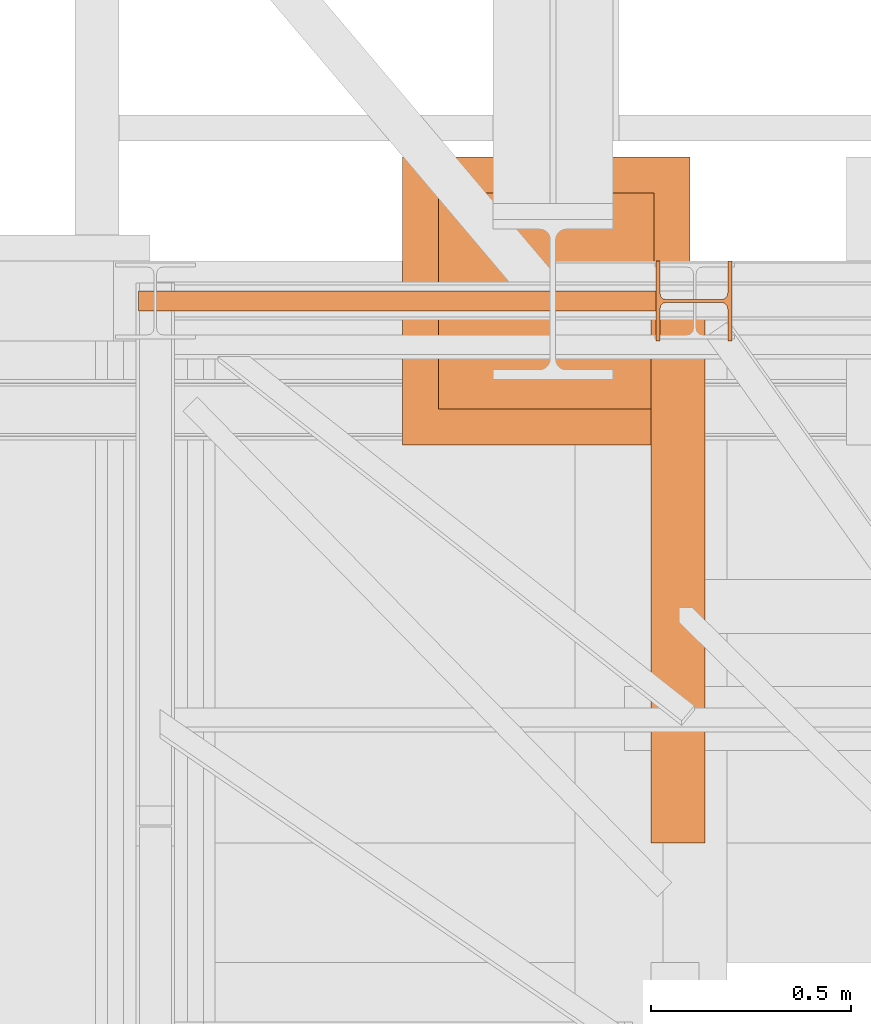
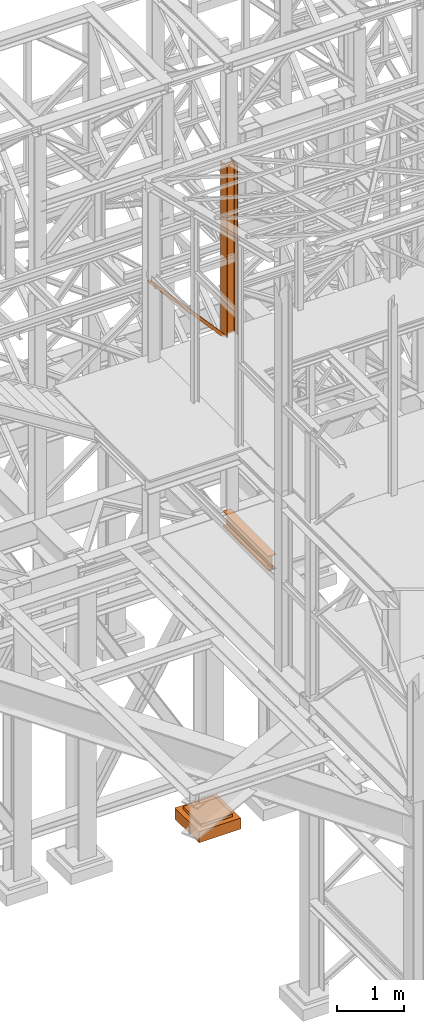
# One storey, part 36 of 208: 4 proxies.
"""IFC2X3 building model written with IfcOpenShell, lengths in millimetres."""

from ifc_helpers import new_model, entity, si_unit, converted_unit, frame, origin, origin_with_axes, place, context, subcontext, project, spatial, faceted_brep, element, save


model = new_model("IFC2X3")

# Units and contexts
model_context = context("Model", 3, precision=1e-05, world=origin())
plan_context = context("Plan", 3, precision=1e-05, world=origin())
body_context = subcontext(model_context, "Body", "Model", "MODEL_VIEW")
ifc_project = project(units=[si_unit("LENGTHUNIT", "METRE", prefix="MILLI"), converted_unit("PLANEANGLEUNIT", "DEGREE", entity("IfcPlaneAngleMeasure", 0.0174532925199433), si_unit("PLANEANGLEUNIT", "RADIAN"), dimensions=[0, 0, 0, 0, 0, 0, 0]), si_unit("AREAUNIT", "SQUARE_METRE"), si_unit("VOLUMEUNIT", "CUBIC_METRE")], contexts=[model_context, plan_context])

# Building, storey
building_placement = place(None, origin())
building = spatial("IfcBuilding", under=ifc_project, at=building_placement, CompositionType="COMPLEX")
storey_placement = place(building_placement, origin_with_axes())
storey = spatial("IfcBuildingStorey", under=building, at=storey_placement, Name="Geschoss", CompositionType="ELEMENT")

# Proxies
proxy_1_placement = place(storey_placement, frame((2438.254968338675, -18618.5743901279, 5014.990005364416), z_axis=(0.0, 0.0, 1.0), x_axis=(1.0, 0.0, 0.0)))
element("IfcBuildingElementProxy", 1, at=proxy_1_placement, inside=storey, context=body_context, shape_type="Brep", body=[
    faceted_brep([(135.0100000000002, 0.01000000000203727, 270.0100000000002), (135.0100000000002, 1361.080528322538, 270.0099999999993), (135.0100000000002, 1361.080528322538, 259.8100001907342), (135.0100000000002, 0.01000000000203727, 259.8100001907342), (135.0100000000002, 0.01000000000203727, 259.8100001907342), (135.0100000000002, 1361.080528322538, 259.8100001907342), (85.8099999523165, 1361.080528322538, 259.8100001907351), (85.8099999523165, 0.01000000000203727, 259.8100001907342), (85.8099999523165, 0.01000000000203727, 259.8100001907342), (85.8099999523165, 1361.080528322538, 259.8100001907351), (81.17476076017192, 1361.080528322538, 259.0757968253229), (81.17476076017192, 0.01000000000203727, 259.0757968253229), (81.17476076017192, 0.01000000000203727, 259.0757968253229), (81.17476076017192, 1361.080528322538, 259.0757968253229), (76.99323602687218, 1361.080528322538, 256.9452365592915), (76.99323602687218, 0.01000000000203727, 256.9452365592915), (76.99323602687218, 0.01000000000203727, 256.9452365592915), (76.99323602687218, 1361.080528322538, 256.9452365592915), (73.67476358376007, 1361.080528322538, 253.6267641161794), (73.67476358376007, 0.01000000000203727, 253.6267641161794), (73.67476358376007, 0.01000000000203727, 253.6267641161794), (73.67476358376007, 1361.080528322538, 253.6267641161794), (71.5442033177278, 1361.080528322538, 249.4452393828788), (71.5442033177278, 0.01000000000203727, 249.4452393828788), (71.5442033177278, 0.01000000000203727, 249.4452393828788), (71.5442033177278, 1361.080528322538, 249.4452393828788), (70.8099999523165, 1361.080528322538, 244.8100001907342), (70.8099999523165, 0.01000000000203727, 244.8100001907342), (70.8099999523165, 0.01000000000203727, 244.8100001907342), (70.8099999523165, 1361.080528322538, 244.8100001907342), (70.8099999523165, 1361.080528322538, 25.20999980926445), (70.8099999523165, 0.01000000000203727, 25.20999980926445), (70.8099999523165, 0.01000000000203727, 25.20999980926445), (70.8099999523165, 1361.080528322538, 25.20999980926445), (71.5442033177278, 1361.080528322538, 20.57476061711986), (71.5442033177278, 0.01000000000203727, 20.57476061711896), (71.5442033177278, 0.01000000000203727, 20.57476061711896), (71.5442033177278, 1361.080528322538, 20.57476061711986), (73.67476358376007, 1361.080528322538, 16.39323588381922), (73.67476358376007, 0.01000000000203727, 16.39323588381922), (73.67476358376007, 0.01000000000203727, 16.39323588381922), (73.67476358376007, 1361.080528322538, 16.39323588381922), (76.99323602687218, 1361.080528322538, 13.07476344070801), (76.99323602687218, 0.01000000000203727, 13.07476344070801), (76.99323602687218, 0.01000000000203727, 13.07476344070801), (76.99323602687218, 1361.080528322538, 13.07476344070801), (81.17476076017192, 1361.080528322538, 10.94420317467666), (81.17476076017192, 0.01000000000203727, 10.94420317467666), (81.17476076017192, 0.01000000000203727, 10.94420317467666), (81.17476076017192, 1361.080528322538, 10.94420317467666), (85.8099999523165, 1361.080528322538, 10.20999980926445), (85.8099999523165, 0.01000000000203727, 10.20999980926445), (85.8099999523165, 0.01000000000203727, 10.20999980926445), (85.8099999523165, 1361.080528322538, 10.20999980926445), (135.0100000000002, 1361.080528322538, 10.20999980926445), (135.0100000000002, 0.01000000000203727, 10.20999980926445), (135.0100000000002, 0.01000000000203727, 10.20999980926445), (135.0100000000002, 1361.080528322538, 10.20999980926445), (135.0100000000002, 1361.080528322538, 0.009999999999308784), (135.0100000000002, 0.01000000000203727, 0.01000000000021828), (135.0100000000002, 0.01000000000203727, 0.01000000000021828), (135.0100000000002, 1361.080528322538, 0.009999999999308784), (0.01000000000021828, 1361.080528322538, 0.009999999999308784), (0.01000000000021828, 0.01000000000203727, 0.01000000000021828), (0.01000000000021828, 0.01000000000203727, 0.01000000000021828), (0.01000000000021828, 1361.080528322538, 0.009999999999308784), (0.01000000000021828, 1361.080528322538, 10.20999980926536), (0.01000000000021828, 0.01000000000203727, 10.20999980926536), (0.01000000000021828, 0.01000000000203727, 10.20999980926536), (0.01000000000021828, 1361.080528322538, 10.20999980926536), (49.21000004768393, 1361.080528322538, 10.20999980926445), (49.21000004768393, 0.01000000000203727, 10.20999980926445), (49.21000004768393, 0.01000000000203727, 10.20999980926445), (49.21000004768393, 1361.080528322538, 10.20999980926445), (53.09227270367228, 1361.080528322538, 10.72115637176103), (53.09227270367228, 0.01000000000203727, 10.72115637176103), (53.09227270367228, 0.01000000000203727, 10.72115637176103), (53.09227270367228, 1361.080528322538, 10.72115637176103), (56.70997817243006, 1361.080528322538, 12.21965904159151), (56.70997817243006, 0.01000000000203727, 12.21965904159151), (56.70997817243006, 0.01000000000203727, 12.21965904159151), (56.70997817243006, 1361.080528322538, 12.21965904159151), (59.81660176548212, 1361.080528322538, 14.60339809146626), (59.81660176548212, 0.01000000000203727, 14.60339809146626), (59.81660176548212, 0.01000000000203727, 14.60339809146626), (59.81660176548212, 1361.080528322538, 14.60339809146626), (62.20034081535778, 1361.080528322538, 17.71002168451923), (62.20034081535778, 0.01000000000203727, 17.71002168451923), (62.20034081535778, 0.01000000000203727, 17.71002168451923), (62.20034081535778, 1361.080528322538, 17.71002168451923), (63.69884348518826, 1361.080528322538, 21.32772715327701), (63.69884348518826, 0.01000000000203727, 21.32772715327701), (63.69884348518826, 0.01000000000203727, 21.32772715327701), (63.69884348518826, 1361.080528322538, 21.32772715327701), (64.21000004768393, 1361.080528322538, 25.20999980926445), (64.21000004768393, 0.01000000000203727, 25.20999980926445), (64.21000004768393, 0.01000000000203727, 25.20999980926445), (64.21000004768393, 1361.080528322538, 25.20999980926445), (64.21000004768393, 1361.080528322538, 244.8100001907342), (64.21000004768393, 0.01000000000203727, 244.8100001907342), (64.21000004768393, 0.01000000000203727, 244.8100001907342), (64.21000004768393, 1361.080528322538, 244.8100001907342), (63.47579668227263, 1361.080528322538, 249.4452393828788), (63.47579668227263, 0.01000000000203727, 249.4452393828788), (63.47579668227263, 0.01000000000203727, 249.4452393828788), (63.47579668227263, 1361.080528322538, 249.4452393828788), (61.34523641624219, 1361.080528322538, 253.6267641161794), (61.34523641624219, 0.01000000000203727, 253.6267641161794), (61.34523641624219, 0.01000000000203727, 253.6267641161794), (61.34523641624219, 1361.080528322538, 253.6267641161794), (58.02676397313007, 1361.080528322538, 256.9452365592915), (58.02676397313007, 0.01000000000203727, 256.9452365592915), (58.02676397313007, 0.01000000000203727, 256.9452365592915), (58.02676397313007, 1361.080528322538, 256.9452365592915), (53.84523923982852, 1361.080528322538, 259.0757968253229), (53.84523923982852, 0.01000000000203727, 259.0757968253229), (53.84523923982852, 0.01000000000203727, 259.0757968253229), (53.84523923982852, 1361.080528322538, 259.0757968253229), (49.21000004768393, 1361.080528322538, 259.8100001907351), (49.21000004768393, 0.01000000000203727, 259.8100001907342), (49.21000004768393, 0.01000000000203727, 259.8100001907342), (49.21000004768393, 1361.080528322538, 259.8100001907351), (0.01000000000021828, 1361.080528322538, 259.8100001907351), (0.01000000000021828, 0.01000000000203727, 259.8100001907342), (0.01000000000021828, 0.01000000000203727, 259.8100001907342), (0.01000000000021828, 1361.080528322538, 259.8100001907351), (0.01000000000021828, 1361.080528322538, 270.0099999999993), (0.01000000000021828, 0.01000000000203727, 270.0099999999993), (0.01000000000021828, 0.01000000000203727, 270.0099999999993), (0.01000000000021828, 1361.080528322538, 270.0099999999993), (135.0100000000002, 1361.080528322538, 270.0099999999993), (135.0100000000002, 0.01000000000203727, 270.0100000000002), (53.84523923982852, 1361.080528322538, 259.0757968253229), (58.02676397313007, 1361.080528322538, 256.9452365592915), (61.34523641624219, 1361.080528322538, 253.6267641161794), (63.47579668227263, 1361.080528322538, 249.4452393828788), (64.21000004768393, 1361.080528322538, 244.8100001907342), (64.21000004768393, 1361.080528322538, 25.20999980926445), (63.69884348518826, 1361.080528322538, 21.32772715327701), (62.20034081535778, 1361.080528322538, 17.71002168451923), (59.81660176548212, 1361.080528322538, 14.60339809146626), (56.70997817243006, 1361.080528322538, 12.21965904159151), (53.09227270367228, 1361.080528322538, 10.72115637176103), (49.21000004768393, 1361.080528322538, 10.20999980926445), (0.01000000000021828, 1361.080528322538, 10.20999980926536), (0.01000000000021828, 1361.080528322538, 0.009999999999308784), (135.0100000000002, 1361.080528322538, 0.009999999999308784), (135.0100000000002, 1361.080528322538, 10.20999980926445), (85.8099999523165, 1361.080528322538, 10.20999980926445), (81.17476076017192, 1361.080528322538, 10.94420317467666), (76.99323602687218, 1361.080528322538, 13.07476344070801), (73.67476358376007, 1361.080528322538, 16.39323588381922), (71.5442033177278, 1361.080528322538, 20.57476061711986), (70.8099999523165, 1361.080528322538, 25.20999980926445), (70.8099999523165, 1361.080528322538, 244.8100001907342), (71.5442033177278, 1361.080528322538, 249.4452393828788), (73.67476358376007, 1361.080528322538, 253.6267641161794), (76.99323602687218, 1361.080528322538, 256.9452365592915), (81.17476076017192, 1361.080528322538, 259.0757968253229), (85.8099999523165, 1361.080528322538, 259.8100001907351), (135.0100000000002, 1361.080528322538, 259.8100001907342), (135.0100000000002, 1361.080528322538, 270.0099999999993), (0.01000000000021828, 1361.080528322538, 270.0099999999993), (0.01000000000021828, 1361.080528322538, 259.8100001907351), (49.21000004768393, 1361.080528322538, 259.8100001907351), (135.0100000000002, 0.01000000000203727, 270.0100000000002), (135.0100000000002, 0.01000000000203727, 259.8100001907342), (85.8099999523165, 0.01000000000203727, 259.8100001907342), (81.17476076017192, 0.01000000000203727, 259.0757968253229), (76.99323602687218, 0.01000000000203727, 256.9452365592915), (73.67476358376007, 0.01000000000203727, 253.6267641161794), (71.5442033177278, 0.01000000000203727, 249.4452393828788), (70.8099999523165, 0.01000000000203727, 244.8100001907342), (70.8099999523165, 0.01000000000203727, 25.20999980926445), (71.5442033177278, 0.01000000000203727, 20.57476061711896), (73.67476358376007, 0.01000000000203727, 16.39323588381922), (76.99323602687218, 0.01000000000203727, 13.07476344070801), (81.17476076017192, 0.01000000000203727, 10.94420317467666), (85.8099999523165, 0.01000000000203727, 10.20999980926445), (135.0100000000002, 0.01000000000203727, 10.20999980926445), (135.0100000000002, 0.01000000000203727, 0.01000000000021828), (0.01000000000021828, 0.01000000000203727, 0.01000000000021828), (0.01000000000021828, 0.01000000000203727, 10.20999980926536), (49.21000004768393, 0.01000000000203727, 10.20999980926445), (53.09227270367228, 0.01000000000203727, 10.72115637176103), (56.70997817243006, 0.01000000000203727, 12.21965904159151), (59.81660176548212, 0.01000000000203727, 14.60339809146626), (62.20034081535778, 0.01000000000203727, 17.71002168451923), (63.69884348518826, 0.01000000000203727, 21.32772715327701), (64.21000004768393, 0.01000000000203727, 25.20999980926445), (64.21000004768393, 0.01000000000203727, 244.8100001907342), (63.47579668227263, 0.01000000000203727, 249.4452393828788), (61.34523641624219, 0.01000000000203727, 253.6267641161794), (58.02676397313007, 0.01000000000203727, 256.9452365592915), (53.84523923982852, 0.01000000000203727, 259.0757968253229), (49.21000004768393, 0.01000000000203727, 259.8100001907342), (0.01000000000021828, 0.01000000000203727, 259.8100001907342), (0.01000000000021828, 0.01000000000203727, 270.0099999999993)], [[[0, 1, 2, 3]], [[4, 5, 6, 7]], [[8, 9, 10, 11]], [[12, 13, 14, 15]], [[16, 17, 18, 19]], [[20, 21, 22, 23]], [[24, 25, 26, 27]], [[28, 29, 30, 31]], [[32, 33, 34, 35]], [[36, 37, 38, 39]], [[40, 41, 42, 43]], [[44, 45, 46, 47]], [[48, 49, 50, 51]], [[52, 53, 54, 55]], [[56, 57, 58, 59]], [[60, 61, 62, 63]], [[64, 65, 66, 67]], [[68, 69, 70, 71]], [[72, 73, 74, 75]], [[76, 77, 78, 79]], [[80, 81, 82, 83]], [[84, 85, 86, 87]], [[88, 89, 90, 91]], [[92, 93, 94, 95]], [[96, 97, 98, 99]], [[100, 101, 102, 103]], [[104, 105, 106, 107]], [[108, 109, 110, 111]], [[112, 113, 114, 115]], [[116, 117, 118, 119]], [[120, 121, 122, 123]], [[124, 125, 126, 127]], [[128, 129, 130, 131]], [[132, 133, 134, 135, 136, 137, 138, 139, 140, 141, 142, 143, 144, 145, 146, 147, 148, 149, 150, 151, 152, 153, 154, 155, 156, 157, 158, 159, 160, 161, 162, 163, 164]], [[165, 166, 167, 168, 169, 170, 171, 172, 173, 174, 175, 176, 177, 178, 179, 180, 181, 182, 183, 184, 185, 186, 187, 188, 189, 190, 191, 192, 193, 194, 195, 196, 197]]], orient=[[False], [False], [False], [False], [False], [False], [False], [False], [False], [False], [False], [False], [False], [False], [False], [False], [False], [False], [False], [False], [False], [False], [False], [False], [False], [False], [False], [False], [False], [False], [False], [False], [False], [False], [False]]),
])
proxy_2_placement = place(storey_placement, frame((1816.730231152619, -17622.57439531565, -315.0099999999999), z_axis=(0.0, 0.0, 1.0), x_axis=(1.0, 0.0, 0.0)))
element("IfcBuildingElementProxy", 2, at=proxy_2_placement, inside=storey, context=body_context, shape_type="Brep", body=[
    faceted_brep([(630.01, 630.0099999999984, 250.01), (630.01, 90.0099999999984, 250.01), (90.00999999999999, 90.0099999999984, 250.01), (90.00999999999999, 630.0099999999984, 250.01), (630.01, 630.0099999999984, 200.01), (630.01, 90.0099999999984, 200.01), (630.01, 90.0099999999984, 250.01), (630.01, 630.0099999999984, 250.01), (90.00999999999999, 630.0099999999984, 200.01), (630.01, 630.0099999999984, 200.01), (630.01, 630.0099999999984, 250.01), (90.00999999999999, 630.0099999999984, 250.01), (90.00999999999999, 90.0099999999984, 200.01), (90.00999999999999, 630.0099999999984, 200.01), (90.00999999999999, 630.0099999999984, 250.01), (90.00999999999999, 90.0099999999984, 250.01), (630.01, 90.0099999999984, 200.01), (90.00999999999999, 90.0099999999984, 200.01), (90.00999999999999, 90.0099999999984, 250.01), (630.01, 90.0099999999984, 250.01), (720.01, 0.00999999999839929, 0.009999999999990905), (720.01, 720.0099999999984, 0.009999999999990905), (0.009999999999990905, 720.0099999999984, 0.009999999999990905), (0.009999999999990905, 0.00999999999839929, 0.009999999999990905), (720.01, 720.0099999999984, 200.01), (720.01, 0.00999999999839929, 200.01), (0.009999999999990905, 0.00999999999839929, 200.01), (0.009999999999990905, 720.0099999999984, 200.01), (90.00999999999999, 90.0099999999984, 200.01), (630.01, 90.0099999999984, 200.01), (630.01, 630.0099999999984, 200.01), (90.00999999999999, 630.0099999999984, 200.01), (720.01, 720.0099999999984, 0.009999999999990905), (720.01, 0.00999999999839929, 0.009999999999990905), (720.01, 0.00999999999839929, 200.01), (720.01, 720.0099999999984, 200.01), (0.009999999999990905, 720.0099999999984, 0.009999999999990905), (720.01, 720.0099999999984, 0.009999999999990905), (720.01, 720.0099999999984, 200.01), (0.009999999999990905, 720.0099999999984, 200.01), (0.009999999999990905, 0.00999999999839929, 0.009999999999990905), (0.009999999999990905, 720.0099999999984, 0.009999999999990905), (0.009999999999990905, 720.0099999999984, 200.01), (0.009999999999990905, 0.00999999999839929, 200.01), (720.01, 0.00999999999839929, 0.009999999999990905), (0.009999999999990905, 0.00999999999839929, 0.009999999999990905), (0.009999999999990905, 0.00999999999839929, 200.01), (720.01, 0.00999999999839929, 200.01)], [[[0, 1, 2, 3]], [[4, 5, 6, 7]], [[8, 9, 10, 11]], [[12, 13, 14, 15]], [[16, 17, 18, 19]], [[20, 21, 22, 23]], [[24, 25, 26, 27], [28, 29, 30, 31]], [[32, 33, 34, 35]], [[36, 37, 38, 39]], [[40, 41, 42, 43]], [[44, 45, 46, 47]]], orient=[[False], [False], [False], [False], [False], [False], [False, False], [False], [False], [False], [False]]),
])
proxy_3_placement = place(storey_placement, frame((2451.004960357815, -17362.574391808, 8484.990002086157), z_axis=(0.0, 0.0, 1.0), x_axis=(1.0, 0.0, 0.0)))
element("IfcBuildingElementProxy", 3, at=proxy_3_placement, inside=storey, context=body_context, shape_type="Brep", body=[
    faceted_brep([(190.0100211920199, 0.00999999999839929, 3115.0099922514), (180.0100232781824, 0.00999999999839929, 3115.0099922514), (180.0100158276027, 78.75999940395195, 3115.0099922514), (178.1454707803196, 88.07581143289644, 3115.0099922514), (171.325827700085, 94.89545311614711, 3115.0099922514), (162.0100166024631, 96.7600014230593, 3115.0099922514), (28.01000581402241, 96.7600014230593, 3115.0099922514), (18.69419471640049, 94.89545311614711, 3115.0099922514), (11.87455163616596, 88.07581143289644, 3115.0099922514), (10.01000658888279, 78.75999940395195, 3115.0099922514), (10.01000658888188, 0.00999999999839929, 3115.0099922514), (0.01000867504444614, 0.00999999999839929, 3115.0099922514), (0.01000867504626513, 200.0100029802306, 3115.0099922514), (10.0100065888837, 200.0100029802306, 3115.0099922514), (10.01000658888279, 121.2600035762771, 3115.0099922514), (11.87455163616596, 111.9441915473326, 3115.0099922514), (18.69419471640049, 105.1245498640819, 3115.0099922514), (28.01000581402241, 103.2600015571697, 3115.0099922514), (162.0100166024631, 103.2600015571697, 3115.0099922514), (171.325827700085, 105.1245498640819, 3115.0099922514), (178.1454707803196, 111.9441915473326, 3115.0099922514), (180.0100158276027, 121.2600035762771, 3115.0099922514), (180.0100232781842, 200.0100029802306, 3115.0099922514), (190.0100211920217, 200.0100029802306, 3115.0099922514), (190.0100211920217, 200.0100029802306, 3115.0099922514), (190.0100125169774, 200.0100029802306, 0.00999999999839929), (190.0100125169756, 0.00999999999839929, 0.00999999999839929), (190.0100211920199, 0.00999999999839929, 3115.0099922514), (180.0100232781842, 200.0100029802306, 3115.0099922514), (180.01001460314, 200.0100029802306, 0.00999999999839929), (190.0100125169774, 200.0100029802306, 0.00999999999839929), (190.0100211920217, 200.0100029802306, 3115.0099922514), (180.0100158276027, 121.2600035762771, 3115.0099922514), (180.0100071525585, 121.2600035762771, 0.00999999999839929), (180.01001460314, 200.0100029802306, 0.00999999999839929), (180.0100232781842, 200.0100029802306, 3115.0099922514), (178.1454707803196, 111.9441915473326, 3115.0099922514), (178.1454621052753, 111.9441915473326, 0.00999999999839929), (180.0100071525585, 121.2600035762771, 0.00999999999839929), (180.0100158276027, 121.2600035762771, 3115.0099922514), (171.325827700085, 105.1245498640819, 3115.0099922514), (171.3258190250408, 105.1245498640819, 0.00999999999839929), (178.1454621052753, 111.9441915473326, 0.00999999999839929), (178.1454707803196, 111.9441915473326, 3115.0099922514), (162.0100166024631, 103.2600015571697, 3115.0099922514), (162.0100079274189, 103.2600015571697, 0.00999999999839929), (171.3258190250408, 105.1245498640819, 0.00999999999839929), (171.325827700085, 105.1245498640819, 3115.0099922514), (28.01000581402241, 103.2600015571697, 3115.0099922514), (28.00999713897818, 103.2600015571697, 0.00999999999839929), (162.0100079274189, 103.2600015571697, 0.00999999999839929), (162.0100166024631, 103.2600015571697, 3115.0099922514), (18.69419471640049, 105.1245498640819, 3115.0099922514), (18.69418604135626, 105.1245498640819, 0.00999999999839929), (28.00999713897818, 103.2600015571697, 0.00999999999839929), (28.01000581402241, 103.2600015571697, 3115.0099922514), (11.87455163616596, 111.9441915473326, 3115.0099922514), (11.87454296112173, 111.9441915473326, 0.00999999999839929), (18.69418604135626, 105.1245498640819, 0.00999999999839929), (18.69419471640049, 105.1245498640819, 3115.0099922514), (10.01000658888279, 121.2600035762771, 3115.0099922514), (10.00999791383856, 121.2600035762771, 0.00999999999839929), (11.87454296112173, 111.9441915473326, 0.00999999999839929), (11.87455163616596, 111.9441915473326, 3115.0099922514), (10.0100065888837, 200.0100029802306, 3115.0099922514), (10.00999791383947, 200.0100029802306, 0.00999999999839929), (10.00999791383856, 121.2600035762771, 0.00999999999839929), (10.01000658888279, 121.2600035762771, 3115.0099922514), (0.01000867504626513, 200.0100029802306, 3115.0099922514), (0.01000000000203727, 200.0100029802306, 0.00999999999839929), (10.00999791383947, 200.0100029802306, 0.00999999999839929), (10.0100065888837, 200.0100029802306, 3115.0099922514), (0.01000867504444614, 0.00999999999839929, 3115.0099922514), (0.01000000000021828, 0.00999999999839929, 0.00999999999839929), (0.01000000000203727, 200.0100029802306, 0.00999999999839929), (0.01000867504626513, 200.0100029802306, 3115.0099922514), (10.01000658888188, 0.00999999999839929, 3115.0099922514), (10.00999791383765, 0.00999999999839929, 0.00999999999839929), (0.01000000000021828, 0.00999999999839929, 0.00999999999839929), (0.01000867504444614, 0.00999999999839929, 3115.0099922514), (10.01000658888279, 78.75999940395195, 3115.0099922514), (10.00999791383856, 78.75999940395195, 0.00999999999839929), (10.00999791383765, 0.00999999999839929, 0.00999999999839929), (10.01000658888188, 0.00999999999839929, 3115.0099922514), (11.87455163616596, 88.07581143289644, 3115.0099922514), (11.87454296112173, 88.07581143289644, 0.00999999999839929), (10.00999791383856, 78.75999940395195, 0.00999999999839929), (10.01000658888279, 78.75999940395195, 3115.0099922514), (18.69419471640049, 94.89545311614711, 3115.0099922514), (18.69418604135626, 94.89545311614711, 0.00999999999839929), (11.87454296112173, 88.07581143289644, 0.00999999999839929), (11.87455163616596, 88.07581143289644, 3115.0099922514), (28.01000581402241, 96.7600014230593, 3115.0099922514), (28.00999713897818, 96.7600014230593, 0.00999999999839929), (18.69418604135626, 94.89545311614711, 0.00999999999839929), (18.69419471640049, 94.89545311614711, 3115.0099922514), (162.0100166024631, 96.7600014230593, 3115.0099922514), (162.0100079274189, 96.7600014230593, 0.00999999999839929), (28.00999713897818, 96.7600014230593, 0.00999999999839929), (28.01000581402241, 96.7600014230593, 3115.0099922514), (171.325827700085, 94.89545311614711, 3115.0099922514), (171.3258190250408, 94.89545311614711, 0.00999999999839929), (162.0100079274189, 96.7600014230593, 0.00999999999839929), (162.0100166024631, 96.7600014230593, 3115.0099922514), (178.1454707803196, 88.07581143289644, 3115.0099922514), (178.1454621052753, 88.07581143289644, 0.00999999999839929), (171.3258190250408, 94.89545311614711, 0.00999999999839929), (171.325827700085, 94.89545311614711, 3115.0099922514), (180.0100158276027, 78.75999940395195, 3115.0099922514), (180.0100071525585, 78.75999940395195, 0.00999999999839929), (178.1454621052753, 88.07581143289644, 0.00999999999839929), (178.1454707803196, 88.07581143289644, 3115.0099922514), (180.0100232781824, 0.00999999999839929, 3115.0099922514), (180.0100146031382, 0.00999999999839929, 0.00999999999839929), (180.0100071525585, 78.75999940395195, 0.00999999999839929), (180.0100158276027, 78.75999940395195, 3115.0099922514), (190.0100211920199, 0.00999999999839929, 3115.0099922514), (190.0100125169756, 0.00999999999839929, 0.00999999999839929), (180.0100146031382, 0.00999999999839929, 0.00999999999839929), (180.0100232781824, 0.00999999999839929, 3115.0099922514), (190.0100125169756, 0.00999999999839929, 0.00999999999839929), (190.0100125169774, 200.0100029802306, 0.00999999999839929), (180.01001460314, 200.0100029802306, 0.00999999999839929), (180.0100071525585, 121.2600035762771, 0.00999999999839929), (178.1454621052753, 111.9441915473326, 0.00999999999839929), (171.3258190250408, 105.1245498640819, 0.00999999999839929), (162.0100079274189, 103.2600015571697, 0.00999999999839929), (28.00999713897818, 103.2600015571697, 0.00999999999839929), (18.69418604135626, 105.1245498640819, 0.00999999999839929), (11.87454296112173, 111.9441915473326, 0.00999999999839929), (10.00999791383856, 121.2600035762771, 0.00999999999839929), (10.00999791383947, 200.0100029802306, 0.00999999999839929), (0.01000000000203727, 200.0100029802306, 0.00999999999839929), (0.01000000000021828, 0.00999999999839929, 0.00999999999839929), (10.00999791383765, 0.00999999999839929, 0.00999999999839929), (10.00999791383856, 78.75999940395195, 0.00999999999839929), (11.87454296112173, 88.07581143289644, 0.00999999999839929), (18.69418604135626, 94.89545311614711, 0.00999999999839929), (28.00999713897818, 96.7600014230593, 0.00999999999839929), (162.0100079274189, 96.7600014230593, 0.00999999999839929), (171.3258190250408, 94.89545311614711, 0.00999999999839929), (178.1454621052753, 88.07581143289644, 0.00999999999839929), (180.0100071525585, 78.75999940395195, 0.00999999999839929), (180.0100146031382, 0.00999999999839929, 0.00999999999839929)], [[[0, 1, 2, 3, 4, 5, 6, 7, 8, 9, 10, 11, 12, 13, 14, 15, 16, 17, 18, 19, 20, 21, 22, 23]], [[24, 25, 26, 27]], [[28, 29, 30, 31]], [[32, 33, 34, 35]], [[36, 37, 38, 39]], [[40, 41, 42, 43]], [[44, 45, 46, 47]], [[48, 49, 50, 51]], [[52, 53, 54, 55]], [[56, 57, 58, 59]], [[60, 61, 62, 63]], [[64, 65, 66, 67]], [[68, 69, 70, 71]], [[72, 73, 74, 75]], [[76, 77, 78, 79]], [[80, 81, 82, 83]], [[84, 85, 86, 87]], [[88, 89, 90, 91]], [[92, 93, 94, 95]], [[96, 97, 98, 99]], [[100, 101, 102, 103]], [[104, 105, 106, 107]], [[108, 109, 110, 111]], [[112, 113, 114, 115]], [[116, 117, 118, 119]], [[120, 121, 122, 123, 124, 125, 126, 127, 128, 129, 130, 131, 132, 133, 134, 135, 136, 137, 138, 139, 140, 141, 142, 143]]], orient=[[False], [False], [False], [False], [False], [False], [False], [False], [False], [False], [False], [False], [False], [False], [False], [False], [False], [False], [False], [False], [False], [False], [False], [False], [False], [False]]),
])
proxy_4_placement = place(storey_placement, frame((1156.503995494019, -17287.57439069042, 8484.990002086157), z_axis=(0.0, 0.0, 1.0), x_axis=(1.0, 0.0, 0.0)))
element("IfcBuildingElementProxy", 4, at=proxy_4_placement, inside=storey, context=body_context, shape_type="Brep", body=[
    faceted_brep([(1304.510962990662, 0.01000000000567525, 19.5301319327009), (40.73573083418137, 0.01000000000567525, 1439.925067016873), (40.73573083418137, 50.01000074506374, 1439.925067016873), (1304.510962990664, 50.01000074506374, 19.5301319327009), (1304.510962990664, 50.01000074506374, 19.5301319327009), (40.73573083418137, 50.01000074506374, 1439.925067016873), (0.009999999999990905, 50.01000074506374, 1438.117904338133), (1.300874909247568, 50.01000074506374, 1409.02709546241), (1254.95284377165, 50.0100007450601, 0.01000000000021828), (1304.510962990662, 50.0100007450601, 0.01000000000021828), (1254.95284377165, 50.0100007450601, 0.01000000000021828), (1.300874909247568, 50.01000074506374, 1409.02709546241), (1.300874909245749, 0.01000000000567525, 1409.027095462412), (1254.95284377165, 0.01000000000203727, 0.01000000000021828), (1254.95284377165, 0.01000000000203727, 0.01000000000021828), (1.300874909245749, 0.01000000000567525, 1409.027095462412), (0.009999999999990905, 0.01000000000567525, 1438.117904338133), (40.73573083418137, 0.01000000000567525, 1439.925067016873), (1304.510962990662, 0.01000000000567525, 19.5301319327009), (1304.510962990662, 0.01000000000203727, 0.01000000000021828), (40.73573083418137, 0.01000000000567525, 1439.925067016873), (0.009999999999990905, 0.01000000000567525, 1438.117904338133), (0.009999999999990905, 50.01000074506374, 1438.117904338133), (40.73573083418137, 50.01000074506374, 1439.925067016873), (0.009999999999990905, 50.01000074506374, 1438.117904338133), (0.009999999999990905, 0.01000000000567525, 1438.117904338133), (1.300874909245749, 0.01000000000567525, 1409.027095462412), (1.300874909247568, 50.01000074506374, 1409.02709546241), (1304.510962990662, 50.0100007450601, 0.01000000000021828), (1254.95284377165, 50.0100007450601, 0.01000000000021828), (1254.95284377165, 0.01000000000203727, 0.01000000000021828), (1304.510962990662, 0.01000000000203727, 0.01000000000021828), (1304.510962990664, 50.01000074506374, 19.5301319327009), (1304.510962990662, 50.0100007450601, 0.01000000000021828), (1304.510962990662, 0.01000000000203727, 0.01000000000021828), (1304.510962990662, 0.01000000000567525, 19.5301319327009)], [[[0, 1, 2, 3]], [[4, 5, 6, 7, 8, 9]], [[10, 11, 12, 13]], [[14, 15, 16, 17, 18, 19]], [[20, 21, 22, 23]], [[24, 25, 26, 27]], [[28, 29, 30, 31]], [[32, 33, 34, 35]]], orient=[[False], [False], [False], [False], [False], [False], [False], [False]]),
])

save(model, "model.ifc")
